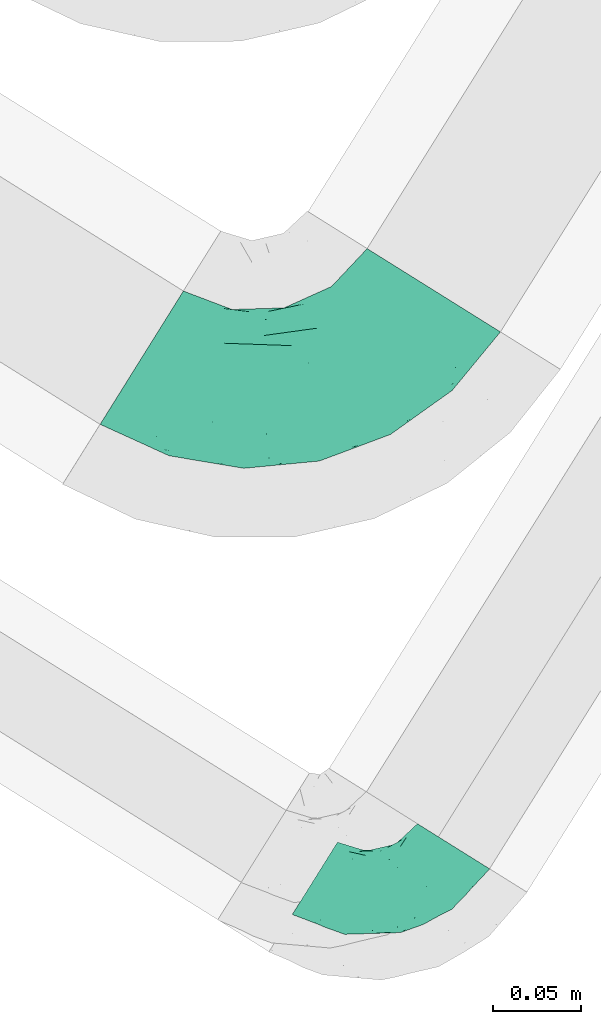
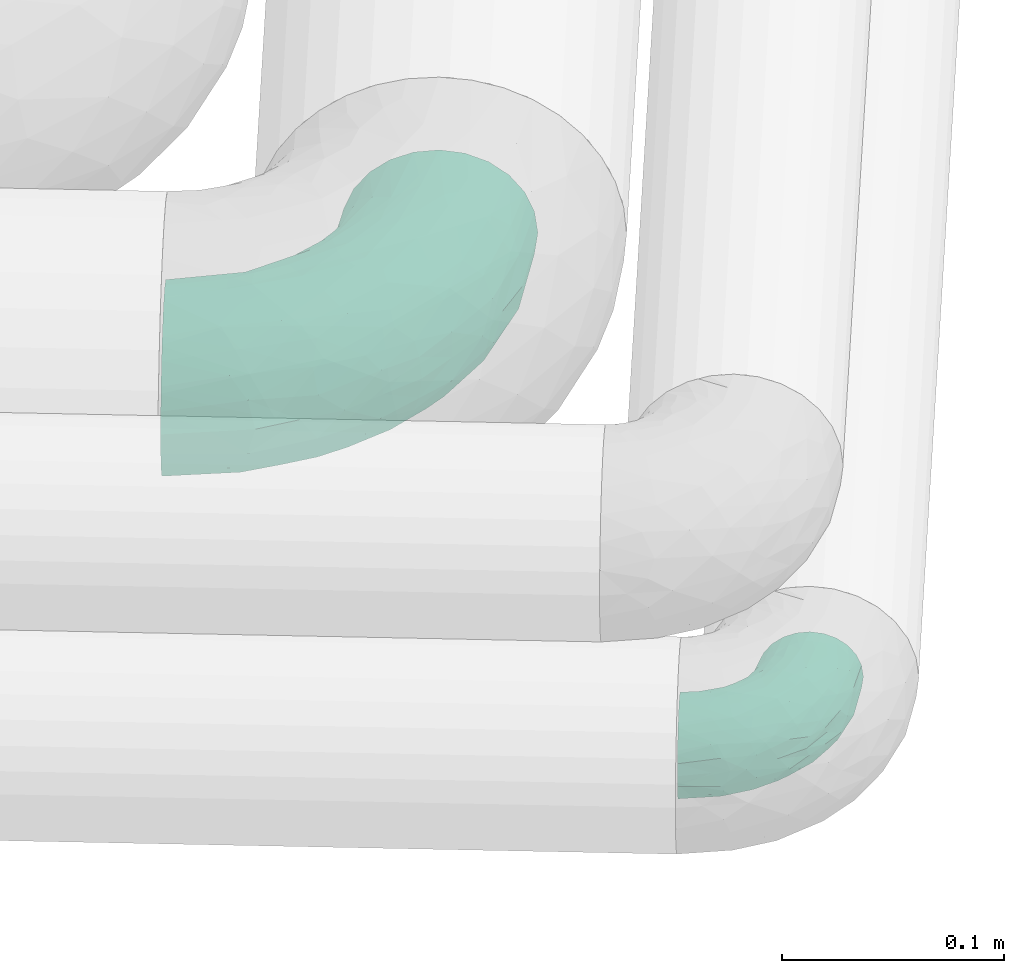
# One storey, part 61 of 93: 2 flow fittings.
"""IFC2X3 building model written with IfcOpenShell, lengths in millimetres."""

import ifcopenshell
import ifcopenshell.guid

model = None  # the IFC model being written
_history = None  # IfcOwnerHistory: only IFC2X3 demands one
_inside = {}  # id of a spatial element -> (the spatial element, [elements in it])
_under = {}  # id of a project, library or spatial element -> (it, [spatial elements below it])
_declared = {}  # id of a project -> (the project, [libraries it declares])
_typed = {}  # id of a type object -> (the type object, [elements of that type])
_made_of = {}  # id of a material, layer set ... -> (it, [elements and type objects made of it])


def new_model(schema):
    """Start an empty IFC model of exactly this schema.

    Asked for "IFC4X3", IfcOpenShell would pick the latest addendum, in which some entities
    have other attributes; the version numbers below select the first issue.
    IFC2X3 requires an IfcOwnerHistory on every rooted entity: one is made here for all.
    """
    global model, _history
    if schema == "IFC4X3":
        model = ifcopenshell.file(schema_version=(4, 3, 0, 0))
    else:
        model = ifcopenshell.file(schema=schema)
    _inside.clear()
    _under.clear()
    _declared.clear()
    _typed.clear()
    _made_of.clear()
    _history = None
    if model.schema == "IFC2X3":
        org = make("IfcOrganization", Name="unknown")
        user = make(
            "IfcPersonAndOrganization",
            ThePerson=make("IfcPerson", FamilyName="unknown"),
            TheOrganization=org,
        )
        app = make(
            "IfcApplication",
            ApplicationDeveloper=org,
            Version="unknown",
            ApplicationFullName="unknown",
            ApplicationIdentifier="unknown",
        )
        _history = make(
            "IfcOwnerHistory",
            OwningUser=user,
            OwningApplication=app,
            ChangeAction="ADDED",
            CreationDate=0,
        )
    return model


def make(cls, **values):
    """One entity of the class cls with the attributes given. An attribute that is None is left unset."""
    return model.create_entity(
        cls, **{name: value for name, value in values.items() if value is not None}
    )


def entity(cls, *values):
    """Any entity or typed value of the class cls, its attributes in the order of the schema. None: left unset."""
    e = model.create_entity(cls)
    for i, value in enumerate(values):
        if value is not None:
            e[i] = value
    return e


def rooted(cls, **values):
    """An entity with a GlobalId (a new one), such as an element, a storey or a relation."""
    return make(cls, GlobalId=ifcopenshell.guid.new(), OwnerHistory=_history, **values)


def si_unit(unit_type, name, prefix=None):
    """IfcSIUnit, for example si_unit("LENGTHUNIT", "METRE", prefix="MILLI")."""
    return make("IfcSIUnit", UnitType=unit_type, Prefix=prefix, Name=name)


def converted_unit(unit_type, name, factor, base, dimensions=None, offset=None):
    """IfcConversionBasedUnit, such as the inch: factor (a typed value) times the base unit."""
    return make(
        "IfcConversionBasedUnit"
        if offset is None
        else "IfcConversionBasedUnitWithOffset",
        ConversionOffset=offset,
        Dimensions=None
        if dimensions is None
        else entity("IfcDimensionalExponents", *dimensions),
        UnitType=unit_type,
        Name=name,
        ConversionFactor=make(
            "IfcMeasureWithUnit", ValueComponent=factor, UnitComponent=base
        ),
    )


def derived_unit(unit_type, elements):
    """IfcDerivedUnit: a product of units, each with its exponent."""
    return make(
        "IfcDerivedUnit",
        Elements=[
            make("IfcDerivedUnitElement", Unit=unit, Exponent=power)
            for unit, power in elements
        ],
        UnitType=unit_type,
    )


def assignment(units):
    """IfcUnitAssignment: the units of a project."""
    return None if units is None else make("IfcUnitAssignment", Units=units)


def point(xyz):
    """IfcCartesianPoint."""
    return None if xyz is None else make("IfcCartesianPoint", Coordinates=xyz)


def direction(xyz):
    """IfcDirection."""
    return None if xyz is None else make("IfcDirection", DirectionRatios=xyz)


def frame(location, z_axis=None, x_axis=None):
    """IfcAxis2Placement3D, a coordinate frame: its origin and axes. An axis left out is left unset."""
    return make(
        "IfcAxis2Placement3D",
        Location=point(location),
        Axis=direction(z_axis),
        RefDirection=direction(x_axis),
    )


def origin():
    """The frame at (0, 0, 0) with its axes left unset."""
    return frame((0.0, 0.0, 0.0))


def place(relative_to, where):
    """IfcLocalPlacement: puts the frame where relative to a parent placement (None: the world)."""
    return make(
        "IfcLocalPlacement", PlacementRelTo=relative_to, RelativePlacement=where
    )


def context(
    kind, dimensions, precision=None, world=None, true_north=None, identifier=None
):
    """IfcGeometricRepresentationContext, for example the 3D "Model" context."""
    return make(
        "IfcGeometricRepresentationContext",
        ContextIdentifier=identifier,
        ContextType=kind,
        CoordinateSpaceDimension=dimensions,
        Precision=precision,
        WorldCoordinateSystem=world,
        TrueNorth=true_north,
    )


def subcontext(parent, identifier, kind, view, scale=None):
    """IfcGeometricRepresentationSubContext, for example "Body" below "Model"."""
    return make(
        "IfcGeometricRepresentationSubContext",
        ContextIdentifier=identifier,
        ContextType=kind,
        ParentContext=parent,
        TargetScale=scale,
        TargetView=view,
    )


def project(units=None, contexts=None):
    """IfcProject with its units and contexts."""
    return rooted(
        "IfcProject",
        Name="project",
        RepresentationContexts=contexts,
        UnitsInContext=assignment(units),
    )


def spatial(cls, under=None, at=None, **own):
    """A site, building, storey or space (cls), placed at a placement, below another one or the project."""
    s = rooted(cls, ObjectPlacement=at, **own)
    if under is not None:
        _under.setdefault(under.id(), (under, []))[1].append(s)
    return s


def faces_of(points, faces, orient=None, outer=None):
    """IfcFace entities. A face is a list of loops; a loop is a list of indices into points, from 0.

    orient and outer hold one flag for each loop. By default every Orientation is true, the
    first loop of a face is its IfcFaceOuterBound and the others are IfcFaceBound.
    """
    made = []
    for i, loops in enumerate(faces):
        bounds = []
        for j, loop in enumerate(loops):
            is_outer = j == 0 if outer is None else outer[i][j]
            bounds.append(
                make(
                    "IfcFaceOuterBound" if is_outer else "IfcFaceBound",
                    Bound=make("IfcPolyLoop", Polygon=[points[k] for k in loop]),
                    Orientation=True if orient is None else orient[i][j],
                )
            )
        made.append(make("IfcFace", Bounds=bounds))
    return made


def faceted_brep(points, faces, orient=None, outer=None, voids=None):
    """IfcFacetedBrep: a solid bounded by flat faces; with voids (closed shells), ...WithVoids."""
    shared = [point(p) for p in points]
    hull = make("IfcClosedShell", CfsFaces=faces_of(shared, faces, orient, outer))
    if voids is None:
        return make("IfcFacetedBrep", Outer=hull)
    return make(
        "IfcFacetedBrepWithVoids",
        Outer=hull,
        Voids=[
            make(cls, CfsFaces=faces_of(shared, fs, o, b)) for cls, fs, o, b in voids
        ],
    )


def shape(context_of_items, identifier, shape_type, items):
    """IfcShapeRepresentation: the items that make up one representation, for example the "Body"."""
    return make(
        "IfcShapeRepresentation",
        ContextOfItems=context_of_items,
        RepresentationIdentifier=identifier,
        RepresentationType=shape_type,
        Items=items,
    )


def source(mapping_origin, context_of_items, identifier, shape_type, items):
    """IfcRepresentationMap: a shape defined once, which mapped items show again and again."""
    return make(
        "IfcRepresentationMap",
        MappingOrigin=mapping_origin,
        MappedRepresentation=shape(context_of_items, identifier, shape_type, items),
    )


def transform(
    local_origin,
    x_axis=None,
    y_axis=None,
    z_axis=None,
    scale=None,
    scale2=None,
    scale3=None,
    uniform=True,
):
    """IfcCartesianTransformationOperator3D, or its non-uniform kind. x_axis, y_axis, z_axis: its Axis1, 2, 3."""
    if uniform:
        return make(
            "IfcCartesianTransformationOperator3D",
            Axis1=direction(x_axis),
            Axis2=direction(y_axis),
            LocalOrigin=point(local_origin),
            Scale=scale,
            Axis3=direction(z_axis),
        )
    return make(
        "IfcCartesianTransformationOperator3DnonUniform",
        Axis1=direction(x_axis),
        Axis2=direction(y_axis),
        LocalOrigin=point(local_origin),
        Scale=scale,
        Axis3=direction(z_axis),
        Scale2=scale2,
        Scale3=scale3,
    )


def mapped(mapping_source, mapping_target):
    """IfcMappedItem: shows the shape of a source again, moved by a transform."""
    return make(
        "IfcMappedItem", MappingSource=mapping_source, MappingTarget=mapping_target
    )


def material(Name=None, Category=None):
    """IfcMaterial."""
    return make("IfcMaterial", Name=Name, Category=Category)


def made_of(thing, what):
    """Note that an element or type object is made of a material, layer set ...; save() writes the relation."""
    if what is not None:
        _made_of.setdefault(what.id(), (what, []))[1].append(thing)
    return thing


def type_object(cls, material=None, **own):
    """A type object (cls), such as IfcWallType, which elements share."""
    return made_of(rooted(cls, **own), material)


def type_shapes(of_type, sources):
    """Give a type object the sources (RepresentationMaps) that its elements show as mapped items."""
    of_type.RepresentationMaps = sources


def element(
    cls,
    number,
    at=None,
    inside=None,
    cuts=None,
    type_object=None,
    material=None,
    context=None,
    identifier="Body",
    shape_type=None,
    held_by="IfcProductDefinitionShape",
    body=None,
    shapes=None,
    **own,
):
    """One element of the class cls, such as IfcWall. Its Tag is "e" and its number.

    at: its placement. inside: the storey or other place that contains it. cuts: it is an
    opening in that element (IfcRelVoidsElement). A single representation is given by context,
    identifier, shape_type and body (its items); several are given by shapes. held_by: the class
    of the entity that holds the representations. save() writes the other relations.
    """
    e = rooted(cls, Tag="e%d" % number, ObjectPlacement=at, **own)
    if body is not None:
        shapes = [shape(context, identifier, shape_type, body)]
    if shapes is not None:
        e.Representation = make(held_by, Representations=shapes)
    if inside is not None:
        _inside.setdefault(inside.id(), (inside, []))[1].append(e)
    if cuts is not None:
        rooted(
            "IfcRelVoidsElement", RelatingBuildingElement=cuts, RelatedOpeningElement=e
        )
    if type_object is not None:
        _typed.setdefault(type_object.id(), (type_object, []))[1].append(e)
    return made_of(e, material)


def aggregate(whole, parts):
    """IfcRelAggregates: a whole, such as a stair, and the parts it consists of."""
    return rooted("IfcRelAggregates", RelatingObject=whole, RelatedObjects=parts)


def save(model, path):
    """Write the relations noted so far, then the file.

    IfcRelAggregates (storeys below a building ...), IfcRelContainedInSpatialStructure (elements
    in a storey), IfcRelDefinesByType, IfcRelAssociatesMaterial and IfcRelDeclares: one each for
    every whole, place, type object, material and project.
    """
    for whole, parts in _under.values():
        aggregate(whole, parts)
    for where, things in _inside.values():
        rooted(
            "IfcRelContainedInSpatialStructure",
            RelatedElements=things,
            RelatingStructure=where,
        )
    for kind, things in _typed.values():
        rooted("IfcRelDefinesByType", RelatedObjects=things, RelatingType=kind)
    for what, things in _made_of.values():
        rooted("IfcRelAssociatesMaterial", RelatedObjects=things, RelatingMaterial=what)
    for by, libraries in _declared.values():
        rooted("IfcRelDeclares", RelatingContext=by, RelatedDefinitions=libraries)
    model.write(path)


model = new_model("IFC2X3")

# Units and contexts
model_context = context("Model", 3, precision=0.01, world=origin(), true_north=direction((6.12303176911189e-17, 1.0)))
body_context = subcontext(model_context, "Body", "Model", "MODEL_VIEW")
ifc_project = project(units=[si_unit("LENGTHUNIT", "METRE", prefix="MILLI"), si_unit("AREAUNIT", "SQUARE_METRE"), si_unit("VOLUMEUNIT", "CUBIC_METRE"), converted_unit("PLANEANGLEUNIT", "DEGREE", entity("IfcRatioMeasure", 0.0174532925199433), si_unit("PLANEANGLEUNIT", "RADIAN"), dimensions=[0, 0, 0, 0, 0, 0, 0]), si_unit("MASSUNIT", "GRAM", prefix="KILO"), derived_unit("MASSDENSITYUNIT", [(si_unit("MASSUNIT", "GRAM", prefix="KILO"), 1), (si_unit("LENGTHUNIT", "METRE"), -3)]), derived_unit("MOMENTOFINERTIAUNIT", [(si_unit("LENGTHUNIT", "METRE"), 4)]), si_unit("TIMEUNIT", "SECOND"), si_unit("FREQUENCYUNIT", "HERTZ"), si_unit("THERMODYNAMICTEMPERATUREUNIT", "DEGREE_CELSIUS"), derived_unit("THERMALTRANSMITTANCEUNIT", [(si_unit("MASSUNIT", "GRAM", prefix="KILO"), 1), (si_unit("THERMODYNAMICTEMPERATUREUNIT", "KELVIN"), -1), (si_unit("TIMEUNIT", "SECOND"), -3)]), derived_unit("VOLUMETRICFLOWRATEUNIT", [(si_unit("LENGTHUNIT", "METRE"), 3), (si_unit("TIMEUNIT", "SECOND"), -1)]), derived_unit("MASSFLOWRATEUNIT", [(si_unit("MASSUNIT", "GRAM", prefix="KILO"), 1), (si_unit("TIMEUNIT", "SECOND"), -1)]), derived_unit("ROTATIONALFREQUENCYUNIT", [(si_unit("TIMEUNIT", "SECOND"), -1)]), si_unit("ELECTRICCURRENTUNIT", "AMPERE"), si_unit("ELECTRICVOLTAGEUNIT", "VOLT"), si_unit("POWERUNIT", "WATT"), si_unit("FORCEUNIT", "NEWTON", prefix="KILO"), si_unit("ILLUMINANCEUNIT", "LUX"), si_unit("LUMINOUSFLUXUNIT", "LUMEN"), si_unit("LUMINOUSINTENSITYUNIT", "CANDELA"), derived_unit("USERDEFINED", [(si_unit("MASSUNIT", "GRAM", prefix="KILO"), -1), (si_unit("LENGTHUNIT", "METRE"), -2), (si_unit("TIMEUNIT", "SECOND"), 3), (si_unit("LUMINOUSFLUXUNIT", "LUMEN"), 1)]), derived_unit("LINEARVELOCITYUNIT", [(si_unit("LENGTHUNIT", "METRE"), 1), (si_unit("TIMEUNIT", "SECOND"), -1)]), si_unit("PRESSUREUNIT", "PASCAL"), derived_unit("USERDEFINED", [(si_unit("LENGTHUNIT", "METRE"), -2), (si_unit("MASSUNIT", "GRAM", prefix="KILO"), 1), (si_unit("TIMEUNIT", "SECOND"), -2)]), derived_unit("LINEARFORCEUNIT", [(si_unit("MASSUNIT", "GRAM", prefix="KILO"), 1), (si_unit("LENGTHUNIT", "METRE"), 1), (si_unit("TIMEUNIT", "SECOND"), -2), (si_unit("LENGTHUNIT", "METRE"), -1)]), derived_unit("PLANARFORCEUNIT", [(si_unit("MASSUNIT", "GRAM", prefix="KILO"), 1), (si_unit("LENGTHUNIT", "METRE"), 1), (si_unit("TIMEUNIT", "SECOND"), -2), (si_unit("LENGTHUNIT", "METRE"), -2)])], contexts=[model_context])

# Site, building, storey
site_placement = place(None, origin())
site = spatial("IfcSite", under=ifc_project, at=site_placement, CompositionType="ELEMENT")
building_placement = place(site_placement, origin())
building = spatial("IfcBuilding", under=site, at=building_placement, CompositionType="ELEMENT")
storey_placement = place(building_placement, frame((0.0, 0.0, -4200.0)))
storey = spatial("IfcBuildingStorey", under=building, at=storey_placement, CompositionType="ELEMENT", Elevation=-4200.0)

# Flow fittings
ifc_material = material()
pipe_fitting_type_1 = type_object("IfcPipeFittingType", Name="ADSK_2", PredefinedType="NOTDEFINED", material=ifc_material)
shared_shape_1 = source(origin(), body_context, "Body", "Brep", [
    faceted_brep([(-120.0, 22.25, -38.54), (-120.0, 11.52, -42.98), (-120.0, 0.0, -44.5), (-120.0, -11.52, -42.98), (-120.0, -22.25, -38.54), (-120.0, -31.47, -31.47), (-120.0, -38.54, -22.25), (-120.0, -42.98, -11.52), (-120.0, -44.5, 0.0), (-120.0, -42.98, 11.52), (-120.0, -38.54, 22.25), (-120.0, -31.47, 31.47), (-120.0, -22.25, 38.54), (-120.0, -11.52, 42.98), (-120.0, 0.0, 44.5), (-120.0, 11.52, 42.98), (-120.0, 22.25, 38.54), (-120.0, 31.47, 31.47), (-120.0, 38.54, 22.25), (-120.0, 42.98, 11.52), (-120.0, 44.5, 0.0), (-120.0, 42.98, -11.52), (-120.0, 38.54, -22.25), (-120.0, 31.47, -31.47), (0.0, 120.0, -44.5), (-11.52, 120.0, -42.98), (-22.25, 120.0, -38.54), (-31.47, 120.0, -31.47), (-38.54, 120.0, -22.25), (-42.98, 120.0, -11.52), (-44.5, 120.0, 0.0), (-42.98, 120.0, 11.52), (-38.54, 120.0, 22.25), (-31.47, 120.0, 31.47), (-22.25, 120.0, 38.54), (-11.52, 120.0, 42.98), (0.0, 120.0, 44.5), (11.52, 120.0, 42.98), (22.25, 120.0, 38.54), (31.47, 120.0, 31.47), (38.54, 120.0, 22.25), (42.98, 120.0, 11.52), (44.5, 120.0, 0.0), (42.98, 120.0, -11.52), (38.54, 120.0, -22.25), (31.47, 120.0, -31.47), (22.25, 120.0, -38.54), (11.52, 120.0, -42.98), (-20.51, 85.66, 41.98), (-29.31, 93.55, 36.45), (-98.0, -41.6, 0.0), (-80.92, -37.22, 14.68), (-66.68, -9.63, 39.67), (-84.59, -24.55, 33.9), (-50.35, -12.87, 32.85), (-77.42, -38.89, 0.0), (-22.01, -9.62, 13.21), (-37.75, -22.46, 0.0), (-20.72, -9.39, 0.0), (-89.18, -33.47, 25.4), (12.87, 50.35, 32.85), (24.55, 84.59, 33.9), (9.63, 66.68, 39.67), (-49.55, -27.06, 11.21), (-28.67, -9.99, 21.67), (-52.01, -22.41, 23.47), (-95.53, -16.28, 40.49), (-86.01, -3.42, 43.77), (22.41, 52.01, 23.47), (9.05, 21.37, 13.44), (26.5, 49.37, 12.73), (33.47, 89.18, 25.4), (37.22, 80.92, 14.68), (16.28, 95.53, 40.49), (3.42, 86.01, 43.77), (-7.84, 52.6, 43.16), (-84.39, 31.88, 36.84), (-30.52, 34.28, 44.33), (-21.99, 28.55, 42.22), (-93.56, 38.23, 28.63), (-65.04, 31.74, 41.51), (-91.98, 19.0, 41.83), (-34.03, 70.24, 39.41), (-96.36, 44.0, 18.64), (-98.49, 46.74, 8.65), (-76.5, 56.97, 9.76), (-4.96, 4.47, 11.32), (-7.16, 6.18, 18.93), (-56.62, 75.93, 12.18), (-66.61, 66.61, 0.0), (-92.12, 7.25, 44.33), (-7.23, 92.66, 44.32), (30.68, 57.59, 0.0), (-44.45, 94.8, 18.75), (-36.39, 101.98, 28.14), (-46.83, 97.45, 9.69), (-38.03, 47.61, 43.21), (-24.7, 65.7, 43.29), (41.6, 98.0, 0.0), (-54.11, 72.8, 21.53), (-47.95, 9.75, 42.93), (-18.65, 18.65, 37.89), (-91.11, 50.25, 0.0), (-50.25, 91.11, 0.0), (-57.59, -30.68, 0.0), (-44.16, 67.2, 34.92), (-55.15, 62.16, 29.74), (-68.1, 47.21, 32.31), (-51.09, 51.09, 38.36), (-16.69, 62.62, 44.46), (-58.26, 18.84, 44.48), (-71.55, 55.71, 20.49), (-43.13, 80.04, 29.45), (-37.23, 0.88, 36.78), (-18.15, 10.22, 33.09), (5.51, 28.08, 26.74), (-3.68, 3.68, 0.0), (9.39, 20.72, 0.0), (-2.58, 27.98, 33.59), (-2.38, 41.22, 38.93), (-16.09, 4.55, 27.06), (38.89, 77.42, 0.0), (22.46, 37.75, 0.0), (-92.66, 7.23, -44.32), (-22.01, -9.62, -13.21), (-49.81, -26.66, -12.91), (-28.67, -9.99, -21.67), (-62.62, 16.69, -44.46), (-65.04, 31.74, -41.51), (-38.89, 47.26, -43.11), (-56.62, 75.93, -12.18), (-93.56, 38.23, -28.63), (-84.39, 31.88, -36.84), (16.28, 95.53, -40.49), (3.42, 86.01, -43.77), (-98.49, 46.74, -8.65), (-44.45, 94.8, -18.75), (-54.11, 72.8, -21.53), (-76.5, 56.97, -9.76), (24.55, 84.59, -33.9), (9.63, 66.68, -39.67), (-96.36, 44.0, -18.64), (-29.4, 93.16, -36.47), (-91.98, 19.0, -41.83), (-80.92, -37.22, -14.68), (-52.6, 7.84, -43.16), (-86.01, -3.42, -43.77), (-89.18, -33.47, -25.4), (-52.01, -22.41, -23.47), (-50.35, -12.87, -32.85), (-84.59, -24.55, -33.9), (-66.68, -9.63, -39.67), (-95.53, -16.28, -40.49), (-68.1, 47.21, -32.31), (-35.81, 11.1, -40.85), (-19.61, 28.53, -41.59), (-18.65, 18.65, -37.89), (-4.97, 4.47, -11.34), (9.05, 21.37, -13.44), (-34.28, 30.52, -44.33), (-9.75, 47.95, -42.93), (-2.58, 27.98, -33.59), (-18.15, 10.22, -33.09), (-46.83, 97.45, -9.69), (12.87, 50.35, -32.85), (26.8, 49.13, -11.4), (-7.34, 92.03, -44.33), (-21.02, 83.86, -42.03), (-44.6, 66.82, -34.8), (-55.46, 62.18, -29.47), (37.22, 80.92, -14.68), (33.47, 89.18, -25.4), (-34.39, 70.11, -39.28), (-25.04, 64.41, -43.37), (-18.84, 58.26, -44.48), (22.41, 52.01, -23.47), (-36.39, 101.98, -28.14), (-51.09, 51.09, -38.36), (-43.13, 80.04, -29.45), (-71.55, 55.71, -20.49), (-7.15, 6.2, -18.94), (5.51, 28.08, -26.74), (-37.23, 0.88, -36.78), (-2.38, 41.22, -38.93), (-16.09, 4.55, -27.06)], [[[0, 1, 2, 3, 4, 5, 6, 7, 8, 9, 10, 11, 12, 13, 14, 15, 16, 17, 18, 19, 20, 21, 22, 23]], [[24, 25, 26, 27, 28, 29, 30, 31, 32, 33, 34, 35, 36, 37, 38, 39, 40, 41, 42, 43, 44, 45, 46, 47]], [[48, 34, 49]], [[50, 51, 9]], [[52, 53, 54]], [[9, 51, 10]], [[55, 51, 50]], [[56, 57, 58]], [[51, 59, 10]], [[60, 61, 62]], [[63, 64, 65]], [[13, 12, 66]], [[67, 14, 13]], [[68, 69, 70]], [[71, 68, 72]], [[38, 73, 61]], [[74, 75, 62]], [[17, 16, 76]], [[77, 78, 75]], [[79, 18, 17]], [[80, 76, 81]], [[35, 34, 48]], [[49, 82, 48]], [[18, 83, 19]], [[16, 81, 76]], [[20, 19, 84]], [[85, 84, 83]], [[56, 86, 87]], [[85, 88, 89]], [[37, 36, 74]], [[90, 14, 67]], [[79, 17, 76]], [[63, 65, 51]], [[13, 66, 67]], [[61, 39, 38]], [[91, 74, 36]], [[70, 92, 72]], [[93, 94, 32]], [[95, 88, 93]], [[62, 73, 74]], [[82, 96, 97]], [[40, 72, 41]], [[72, 68, 70]], [[71, 72, 40]], [[34, 33, 49]], [[72, 98, 41]], [[99, 93, 88]], [[71, 39, 61]], [[78, 100, 101]], [[85, 89, 102]], [[53, 52, 66]], [[103, 95, 30]], [[12, 11, 53]], [[103, 89, 88]], [[104, 57, 63]], [[91, 48, 97]], [[93, 32, 31]], [[33, 32, 94]], [[16, 15, 81]], [[105, 106, 107]], [[76, 107, 79]], [[35, 91, 36]], [[80, 96, 108]], [[31, 95, 93]], [[65, 53, 59]], [[73, 38, 37]], [[75, 74, 109]], [[61, 60, 68]], [[11, 10, 59]], [[54, 53, 65]], [[100, 67, 52]], [[110, 81, 90]], [[15, 14, 90]], [[76, 80, 108]], [[107, 76, 108]], [[83, 79, 111]], [[94, 49, 33]], [[82, 105, 108]], [[84, 85, 102]], [[111, 88, 85]], [[99, 88, 111]], [[94, 93, 112]], [[48, 91, 35]], [[74, 91, 109]], [[69, 87, 86]], [[113, 54, 114]], [[64, 56, 87]], [[60, 115, 68]], [[116, 117, 86]], [[69, 68, 115]], [[79, 83, 18]], [[85, 83, 111]], [[81, 110, 80]], [[110, 77, 96]], [[110, 96, 80]], [[97, 96, 109]], [[107, 108, 105]], [[111, 79, 107]], [[77, 75, 109]], [[118, 119, 101]], [[96, 77, 109]], [[77, 110, 100]], [[67, 100, 110]], [[100, 52, 113]], [[60, 119, 118]], [[118, 120, 115]], [[64, 54, 65]], [[114, 120, 118]], [[118, 115, 60]], [[115, 120, 87]], [[74, 73, 37]], [[61, 73, 62]], [[53, 66, 12]], [[67, 66, 52]], [[110, 90, 67]], [[15, 90, 81]], [[105, 49, 112]], [[96, 82, 108]], [[119, 60, 62]], [[118, 101, 114]], [[62, 75, 119]], [[78, 119, 75]], [[49, 105, 82]], [[105, 112, 106]], [[99, 112, 93]], [[111, 107, 106]], [[113, 114, 101]], [[54, 120, 114]], [[100, 113, 101]], [[52, 54, 113]], [[20, 84, 102]], [[83, 84, 19]], [[111, 106, 99]], [[112, 99, 106]], [[100, 78, 77]], [[119, 78, 101]], [[39, 71, 40]], [[68, 71, 61]], [[65, 59, 51]], [[11, 59, 53]], [[30, 95, 31]], [[103, 88, 95]], [[9, 8, 50]], [[98, 72, 121]], [[98, 42, 41]], [[49, 94, 112]], [[56, 63, 57]], [[51, 55, 104]], [[92, 121, 72]], [[86, 58, 116]], [[54, 64, 120]], [[115, 87, 69]], [[120, 64, 87]], [[58, 86, 56]], [[86, 117, 69]], [[91, 97, 109]], [[122, 69, 117]], [[82, 97, 48]], [[63, 56, 64]], [[104, 63, 51]], [[69, 122, 70]], [[92, 70, 122]], [[123, 2, 1]], [[124, 125, 126]], [[127, 128, 129]], [[103, 130, 89]], [[23, 131, 132]], [[47, 133, 134]], [[102, 135, 20]], [[130, 136, 137]], [[102, 138, 135]], [[139, 140, 133]], [[22, 21, 141]], [[27, 26, 142]], [[46, 45, 139]], [[0, 143, 1]], [[6, 144, 7]], [[145, 146, 127]], [[144, 50, 7]], [[147, 148, 144]], [[144, 6, 147]], [[149, 150, 151]], [[4, 3, 152]], [[23, 22, 131]], [[132, 131, 153]], [[43, 42, 98]], [[125, 104, 144]], [[154, 155, 156]], [[146, 151, 152]], [[4, 150, 5]], [[123, 146, 2]], [[157, 158, 117]], [[130, 138, 89]], [[29, 28, 136]], [[159, 160, 155]], [[161, 162, 156]], [[89, 138, 102]], [[163, 30, 29]], [[164, 140, 139]], [[163, 136, 130]], [[23, 132, 0]], [[158, 165, 122]], [[25, 24, 166]], [[0, 132, 143]], [[4, 152, 150]], [[142, 26, 167]], [[3, 2, 146]], [[167, 26, 25]], [[133, 47, 46]], [[168, 153, 169]], [[146, 145, 151]], [[149, 126, 148]], [[44, 170, 171]], [[24, 47, 134]], [[170, 44, 43]], [[144, 148, 125]], [[170, 98, 121]], [[168, 142, 172]], [[129, 173, 174]], [[98, 170, 43]], [[147, 5, 150]], [[157, 58, 124]], [[92, 122, 165]], [[134, 166, 24]], [[175, 139, 171]], [[28, 27, 176]], [[29, 136, 163]], [[132, 128, 143]], [[45, 44, 171]], [[164, 139, 175]], [[160, 134, 140]], [[174, 173, 166]], [[141, 131, 22]], [[132, 153, 177]], [[128, 132, 177]], [[123, 143, 127]], [[172, 142, 167]], [[176, 142, 178]], [[130, 179, 138]], [[138, 179, 141]], [[176, 136, 28]], [[130, 137, 179]], [[174, 166, 134]], [[167, 25, 166]], [[143, 123, 1]], [[146, 123, 127]], [[150, 149, 148]], [[157, 124, 180]], [[181, 161, 164]], [[181, 158, 180]], [[124, 126, 180]], [[170, 165, 175]], [[141, 21, 135]], [[131, 141, 179]], [[131, 179, 153]], [[179, 137, 169]], [[129, 128, 177]], [[127, 143, 128]], [[129, 177, 172]], [[129, 174, 159]], [[159, 145, 127]], [[182, 154, 156]], [[129, 159, 127]], [[159, 174, 160]], [[134, 160, 174]], [[140, 164, 183]], [[162, 182, 156]], [[126, 149, 184]], [[181, 164, 175]], [[164, 161, 183]], [[158, 181, 175]], [[184, 162, 161]], [[146, 152, 3]], [[150, 152, 151]], [[139, 133, 46]], [[134, 133, 140]], [[184, 161, 181]], [[161, 156, 183]], [[155, 183, 156]], [[160, 140, 183]], [[184, 149, 162]], [[182, 162, 149]], [[149, 151, 182]], [[154, 151, 145]], [[151, 154, 182]], [[159, 154, 145]], [[159, 155, 154]], [[183, 155, 160]], [[141, 135, 138]], [[20, 135, 21]], [[136, 178, 137]], [[169, 178, 168]], [[172, 167, 173]], [[168, 172, 177]], [[153, 168, 177]], [[142, 168, 178]], [[179, 169, 153]], [[137, 178, 169]], [[5, 147, 6]], [[148, 147, 150]], [[175, 171, 170]], [[45, 171, 139]], [[130, 103, 163]], [[30, 163, 103]], [[50, 144, 55]], [[50, 8, 7]], [[142, 176, 27]], [[136, 176, 178]], [[126, 125, 148]], [[104, 55, 144]], [[170, 121, 92]], [[58, 57, 124]], [[180, 126, 184]], [[181, 180, 184]], [[180, 158, 157]], [[158, 122, 117]], [[58, 157, 116]], [[172, 173, 129]], [[116, 157, 117]], [[166, 173, 167]], [[124, 57, 125]], [[104, 125, 57]], [[175, 165, 158]], [[92, 165, 170]]]),
])
type_shapes(pipe_fitting_type_1, [shared_shape_1])
flow_fitting_1_placement = place(storey_placement, frame((13375.54, 6596.39, 3000.76), z_axis=(-4.71165492987562e-05, 2.9441687536031e-05, 1.0), x_axis=(0.848048094847554, -0.529919263415335, 5.5558817327148e-05)))
element("IfcFlowFitting", 1, at=flow_fitting_1_placement, inside=storey, type_object=pipe_fitting_type_1, material=ifc_material, Name="ADSK_2", ObjectType="ADSK_2", context=body_context, shape_type="MappedRepresentation", body=[
    mapped(shared_shape_1, transform((0.0, 0.0, 0.0), scale=1.0)),
])
pipe_fitting_type_2 = type_object("IfcPipeFittingType", Name="ADSK_1", PredefinedType="NOTDEFINED", material=ifc_material)
shared_shape_2 = source(origin(), body_context, "Body", "Brep", [
    faceted_brep([(-57.0, 12.07, -20.91), (-57.0, 6.25, -23.33), (-57.0, 0.0, -24.15), (-57.0, -6.25, -23.33), (-57.0, -12.08, -20.91), (-57.0, -17.08, -17.08), (-57.0, -20.91, -12.08), (-57.0, -23.33, -6.25), (-57.0, -24.15, 0.0), (-57.0, -23.33, 6.25), (-57.0, -20.91, 12.07), (-57.0, -17.08, 17.08), (-57.0, -12.08, 20.91), (-57.0, -6.25, 23.33), (-57.0, 0.0, 24.15), (-57.0, 6.25, 23.33), (-57.0, 12.07, 20.91), (-57.0, 17.08, 17.08), (-57.0, 20.91, 12.07), (-57.0, 23.33, 6.25), (-57.0, 24.15, 0.0), (-57.0, 23.33, -6.25), (-57.0, 20.91, -12.08), (-57.0, 17.08, -17.08), (0.0, 57.0, -24.15), (-6.25, 57.0, -23.33), (-12.07, 57.0, -20.91), (-17.08, 57.0, -17.08), (-20.91, 57.0, -12.08), (-23.33, 57.0, -6.25), (-24.15, 57.0, 0.0), (-23.33, 57.0, 6.25), (-20.91, 57.0, 12.07), (-17.08, 57.0, 17.08), (-12.07, 57.0, 20.91), (-6.25, 57.0, 23.33), (0.0, 57.0, 24.15), (6.25, 57.0, 23.33), (12.08, 57.0, 20.91), (17.08, 57.0, 17.08), (20.91, 57.0, 12.07), (23.33, 57.0, 6.25), (24.15, 57.0, 0.0), (23.33, 57.0, -6.25), (20.91, 57.0, -12.08), (17.08, 57.0, -17.08), (12.08, 57.0, -20.91), (6.25, 57.0, -23.33), (14.9, 21.14, 6.17), (13.61, 24.64, 12.48), (6.23, 8.95, 8.98), (-41.47, -21.06, 0.0), (-41.92, -18.38, 13.72), (-24.64, -13.61, 12.48), (-37.37, -13.24, 18.15), (-6.8, -4.93, 8.18), (-21.76, -15.19, 6.22), (-12.78, -9.18, 0.0), (-37.73, -20.51, 7.75), (-7.38, 7.38, 20.24), (-23.37, -4.26, 20.42), (-11.9, -3.19, 15.86), (-42.14, -8.7, 21.82), (13.24, 37.37, 18.15), (9.33, 23.53, 16.85), (4.26, 23.37, 20.42), (2.77, 10.92, 15.55), (-29.46, 0.91, 23.52), (-44.13, 20.56, 15.69), (-39.25, 26.33, 10.88), (-49.02, 22.92, 9.96), (-34.58, 23.87, 17.15), (-15.8, 6.8, 22.81), (-8.67, 20.47, 23.88), (-18.12, 12.9, 24.08), (-48.29, 14.92, 19.65), (-44.06, -2.85, 23.78), (-9.23, 48.95, 22.58), (-3.78, 42.74, 24.07), (-40.34, 4.26, 24.09), (-44.02, 26.14, 5.46), (-44.04, 9.88, 22.74), (-4.95, 16.87, 22.52), (-2.75, 1.43, 12.5), (-25.48, 40.98, 10.71), (20.51, 37.73, 7.75), (18.38, 41.92, 13.72), (8.7, 42.14, 21.82), (-25.95, -17.97, 0.0), (2.85, 44.06, 23.78), (21.06, 41.47, 0.0), (17.97, 25.95, 0.0), (-24.04, -9.27, 17.13), (-33.26, 33.26, 5.86), (-28.55, 40.57, 0.0), (-40.57, 28.55, 0.0), (-25.29, 47.19, 4.06), (-27.01, 31.1, 16.77), (-15.7, 43.95, 19.9), (-20.27, 45.22, 15.61), (-30.53, 31.98, 12.64), (-11.28, 38.33, 22.92), (-9.97, 27.88, 24.09), (-20.15, 30.26, 21.25), (-31.25, 11.75, 23.64), (-28.75, 7.23, 24.15), (-29.53, 18.06, 22.27), (-28.44, 24.21, 20.02), (-37.55, 17.7, 20.26), (-15.88, 29.25, 22.99), (-20.82, 20.82, 23.44), (-0.91, 29.46, 23.52), (-13.5, -7.67, 12.04), (1.49, 1.56, 5.16), (8.86, 10.35, 4.59), (0.38, -0.38, 0.0), (9.18, 12.78, 0.0), (-37.37, -13.24, -18.15), (8.86, 10.35, -4.59), (-45.22, 20.27, -15.61), (-43.95, 15.7, -19.9), (-38.33, 11.28, -22.92), (-48.95, 9.23, -22.58), (-47.19, 25.29, -4.06), (-33.26, 33.26, -5.86), (18.38, 41.92, -13.72), (-30.26, 20.15, -21.25), (2.85, 44.06, -23.78), (-4.26, 40.34, -24.09), (-40.98, 25.48, -10.71), (-41.92, -18.38, -13.72), (9.25, 23.5, -16.92), (4.26, 23.37, -20.42), (13.24, 37.37, -18.15), (-37.73, -20.51, -7.75), (-11.75, 31.25, -23.64), (-7.23, 28.75, -24.15), (-12.9, 18.12, -24.08), (8.7, 42.14, -21.82), (-44.06, -2.85, -23.78), (-6.8, 15.8, -22.81), (-20.47, 8.67, -23.88), (-24.64, -13.61, -12.48), (-42.74, 3.78, -24.07), (-18.06, 29.53, -22.27), (-24.21, 28.44, -20.02), (-27.88, 9.97, -24.09), (-31.1, 27.01, -16.77), (-26.14, 44.02, -5.46), (14.9, 21.14, -6.17), (20.51, 37.73, -7.75), (-9.88, 44.04, -22.74), (-20.56, 44.13, -15.69), (-21.76, -15.19, -6.22), (-13.5, -7.67, -12.04), (-24.14, -9.76, -16.74), (-11.9, -3.19, -15.86), (-14.92, 48.29, -19.65), (-23.37, -4.26, -20.42), (-0.91, 29.46, -23.52), (-26.33, 39.25, -10.88), (-23.87, 34.58, -17.15), (-42.14, -8.7, -21.82), (-22.92, 49.02, -9.96), (13.61, 24.64, -12.48), (-31.98, 30.53, -12.64), (-16.87, 4.95, -22.52), (-17.7, 37.55, -20.26), (-29.25, 15.88, -22.99), (-20.82, 20.82, -23.44), (-29.46, 0.91, -23.52), (-7.38, 7.38, -20.24), (2.77, 10.92, -15.55), (6.23, 8.95, -8.98), (-6.8, -4.93, -8.18), (-2.81, 1.41, -12.54), (1.49, 1.56, -5.16)], [[[0, 1, 2, 3, 4, 5, 6, 7, 8, 9, 10, 11, 12, 13, 14, 15, 16, 17, 18, 19, 20, 21, 22, 23]], [[24, 25, 26, 27, 28, 29, 30, 31, 32, 33, 34, 35, 36, 37, 38, 39, 40, 41, 42, 43, 44, 45, 46, 47]], [[48, 49, 50]], [[9, 8, 51]], [[52, 53, 54]], [[55, 56, 57]], [[10, 58, 52]], [[9, 58, 10]], [[59, 60, 61]], [[54, 12, 11]], [[54, 62, 12]], [[63, 39, 38]], [[64, 65, 66]], [[62, 60, 67]], [[68, 69, 70]], [[71, 69, 68]], [[72, 73, 74]], [[16, 75, 17]], [[13, 76, 14]], [[35, 77, 78]], [[14, 79, 15]], [[17, 68, 18]], [[14, 76, 79]], [[20, 19, 80]], [[70, 19, 18]], [[81, 15, 79]], [[15, 81, 16]], [[73, 72, 82]], [[66, 83, 50]], [[32, 31, 84]], [[85, 86, 49]], [[63, 87, 65]], [[56, 58, 88]], [[36, 89, 37]], [[85, 41, 40]], [[36, 35, 78]], [[90, 41, 85]], [[40, 39, 86]], [[12, 62, 13]], [[86, 85, 40]], [[48, 85, 49]], [[85, 91, 90]], [[87, 38, 37]], [[92, 60, 54]], [[80, 69, 93]], [[93, 94, 95]], [[10, 52, 11]], [[94, 96, 30]], [[97, 98, 99]], [[80, 93, 95]], [[100, 97, 84]], [[99, 98, 33]], [[101, 102, 78]], [[103, 101, 98]], [[96, 31, 30]], [[77, 98, 101]], [[77, 35, 34]], [[34, 33, 98]], [[9, 51, 58]], [[87, 63, 38]], [[104, 105, 74]], [[106, 103, 107]], [[106, 81, 104]], [[75, 68, 17]], [[108, 107, 71]], [[33, 32, 99]], [[109, 103, 110]], [[101, 109, 102]], [[89, 78, 111]], [[53, 52, 58]], [[54, 11, 52]], [[60, 62, 54]], [[88, 58, 51]], [[76, 62, 67]], [[53, 112, 92]], [[60, 59, 72]], [[39, 63, 86]], [[49, 86, 63]], [[89, 87, 37]], [[42, 41, 90]], [[111, 82, 65]], [[111, 65, 87]], [[65, 59, 66]], [[104, 81, 79]], [[75, 81, 108]], [[32, 84, 99]], [[97, 99, 84]], [[98, 97, 103]], [[106, 107, 108]], [[74, 102, 110]], [[111, 78, 102]], [[74, 110, 104]], [[74, 67, 72]], [[61, 92, 112]], [[66, 59, 61]], [[56, 53, 58]], [[66, 50, 49]], [[61, 112, 83]], [[66, 49, 64]], [[78, 89, 36]], [[87, 89, 111]], [[62, 76, 13]], [[79, 76, 67]], [[100, 93, 69]], [[96, 93, 84]], [[55, 113, 50]], [[113, 114, 50]], [[104, 79, 105]], [[106, 104, 110]], [[20, 80, 95]], [[85, 48, 91]], [[115, 114, 113]], [[116, 91, 48]], [[70, 80, 19]], [[93, 96, 94]], [[84, 31, 96]], [[103, 106, 110]], [[81, 106, 108]], [[103, 97, 107]], [[71, 107, 97]], [[71, 97, 100]], [[108, 71, 68]], [[79, 67, 105]], [[67, 74, 105]], [[115, 113, 57]], [[112, 56, 55]], [[56, 88, 57]], [[60, 72, 67]], [[82, 72, 59]], [[65, 82, 59]], [[82, 111, 73]], [[111, 102, 73]], [[102, 74, 73]], [[81, 75, 16]], [[68, 75, 108]], [[68, 70, 18]], [[80, 70, 69]], [[98, 77, 34]], [[78, 77, 101]], [[93, 100, 84]], [[71, 100, 69]], [[102, 109, 110]], [[101, 103, 109]], [[53, 92, 54]], [[61, 60, 92]], [[56, 112, 53]], [[83, 112, 55]], [[50, 83, 55]], [[61, 83, 66]], [[49, 63, 64]], [[65, 64, 63]], [[57, 113, 55]], [[114, 115, 116]], [[116, 48, 114]], [[48, 50, 114]], [[117, 5, 4]], [[116, 115, 118]], [[119, 120, 23]], [[121, 122, 120]], [[95, 123, 20]], [[0, 23, 120]], [[124, 95, 94]], [[125, 45, 44]], [[121, 120, 126]], [[24, 127, 128]], [[22, 21, 129]], [[0, 122, 1]], [[5, 117, 130]], [[131, 132, 133]], [[134, 88, 51]], [[135, 136, 137]], [[6, 5, 130]], [[46, 138, 47]], [[139, 3, 2]], [[140, 141, 137]], [[6, 134, 7]], [[134, 130, 142]], [[143, 2, 1]], [[144, 126, 145]], [[121, 146, 143]], [[147, 120, 119]], [[94, 148, 124]], [[149, 150, 91]], [[30, 29, 148]], [[151, 25, 128]], [[27, 152, 28]], [[134, 153, 88]], [[154, 155, 156]], [[27, 26, 157]], [[151, 26, 25]], [[155, 158, 156]], [[24, 47, 127]], [[1, 122, 143]], [[138, 132, 159]], [[160, 152, 161]], [[24, 128, 25]], [[46, 133, 138]], [[162, 117, 4]], [[148, 160, 124]], [[152, 160, 163]], [[154, 142, 155]], [[45, 125, 133]], [[133, 46, 45]], [[125, 164, 133]], [[51, 7, 134]], [[42, 90, 43]], [[165, 147, 129]], [[153, 134, 142]], [[43, 150, 44]], [[162, 4, 3]], [[141, 140, 166]], [[117, 162, 158]], [[163, 29, 28]], [[43, 90, 150]], [[123, 21, 20]], [[144, 151, 135]], [[157, 152, 27]], [[167, 145, 161]], [[23, 22, 119]], [[168, 126, 169]], [[121, 168, 146]], [[139, 143, 170]], [[142, 130, 117]], [[8, 7, 51]], [[134, 6, 130]], [[139, 162, 3]], [[170, 166, 158]], [[170, 158, 162]], [[158, 171, 156]], [[44, 150, 125]], [[91, 150, 90]], [[164, 125, 150]], [[132, 138, 133]], [[127, 138, 159]], [[131, 164, 172]], [[132, 171, 140]], [[135, 151, 128]], [[157, 151, 167]], [[22, 129, 119]], [[147, 119, 129]], [[120, 147, 126]], [[144, 145, 167]], [[137, 146, 169]], [[170, 143, 146]], [[137, 169, 135]], [[137, 159, 140]], [[171, 172, 156]], [[173, 174, 175]], [[156, 175, 154]], [[174, 57, 153]], [[132, 172, 171]], [[172, 164, 173]], [[143, 139, 2]], [[162, 139, 170]], [[138, 127, 47]], [[128, 127, 159]], [[165, 124, 160]], [[123, 124, 129]], [[149, 173, 164]], [[176, 174, 173]], [[135, 128, 136]], [[144, 135, 169]], [[150, 149, 164]], [[176, 118, 115]], [[149, 91, 116]], [[30, 148, 94]], [[163, 148, 29]], [[124, 123, 95]], [[129, 21, 123]], [[126, 144, 169]], [[151, 144, 167]], [[126, 147, 145]], [[161, 145, 147]], [[161, 147, 165]], [[167, 161, 152]], [[128, 159, 136]], [[159, 137, 136]], [[154, 153, 142]], [[132, 140, 159]], [[174, 176, 57]], [[57, 88, 153]], [[166, 140, 171]], [[158, 166, 171]], [[166, 170, 141]], [[170, 146, 141]], [[146, 137, 141]], [[151, 157, 26]], [[152, 157, 167]], [[152, 163, 28]], [[148, 163, 160]], [[120, 122, 0]], [[143, 122, 121]], [[124, 165, 129]], [[161, 165, 160]], [[146, 168, 169]], [[121, 126, 168]], [[142, 117, 155]], [[158, 155, 117]], [[175, 156, 172]], [[153, 154, 174]], [[173, 175, 172]], [[174, 154, 175]], [[164, 131, 133]], [[172, 132, 131]], [[176, 173, 118]], [[57, 176, 115]], [[173, 149, 118]], [[149, 116, 118]]]),
])
type_shapes(pipe_fitting_type_2, [shared_shape_2])
flow_fitting_2_placement = place(storey_placement, frame((13420.13, 6335.01, 2942.84), z_axis=(0.0, 0.0, 1.0), x_axis=(0.848048096156422, -0.529919264233211, 0.0)))
element("IfcFlowFitting", 2, at=flow_fitting_2_placement, inside=storey, type_object=pipe_fitting_type_2, material=ifc_material, Name="ADSK_1", ObjectType="ADSK_1", context=body_context, shape_type="MappedRepresentation", body=[
    mapped(shared_shape_2, transform((0.0, 0.0, 0.0), scale=1.0)),
])

save(model, "model.ifc")
